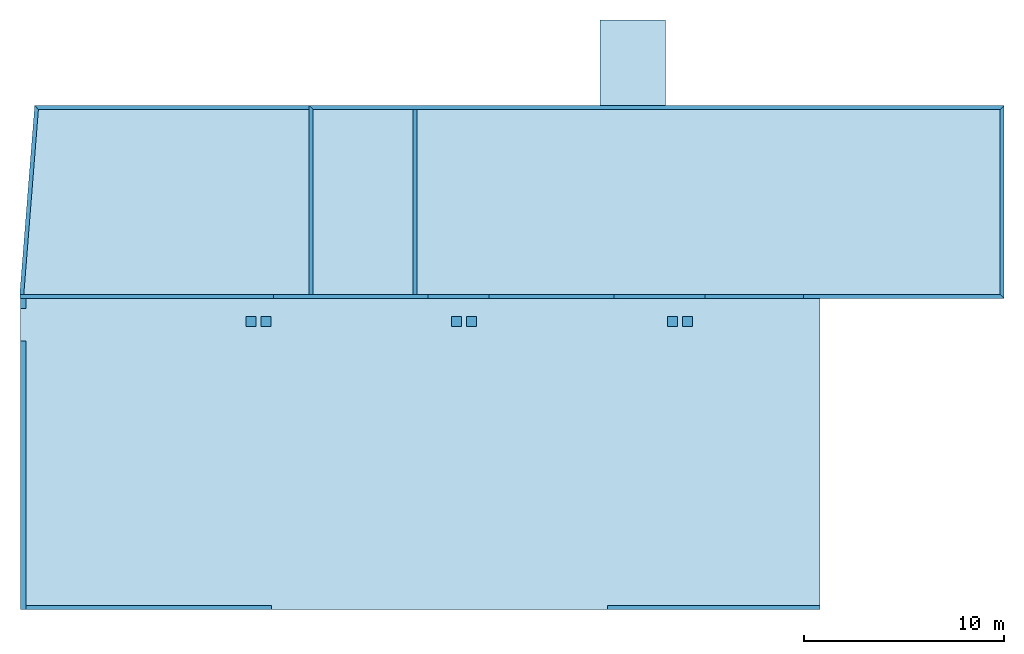
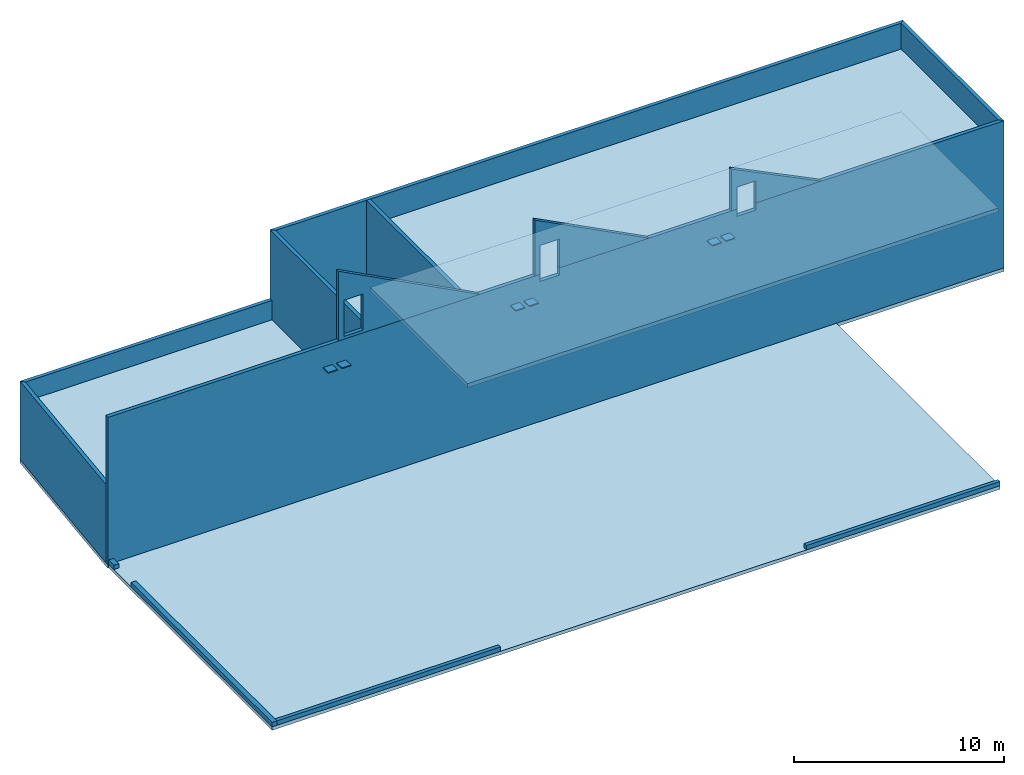
# One storey: 17 beams, 9 slabs.
"""IFC2X3 building model written with IfcOpenShell, lengths in millimetres."""

from ifc_helpers import new_model, si_unit, frame, origin_with_axes, origin_2d_with_axis, place, context, subcontext, project, spatial, polyline, rectangle, outline, extrude, boolean, clip, halfspace, material, layer, layer_set, layer_usage, type_object, element, save


model = new_model("IFC2X3")

# Units and contexts
model_context = context("Model", 3, precision=1e-05, world=origin_with_axes())
body_context = subcontext(model_context, "Body", "Model", "MODEL_VIEW")
ifc_project = project(units=[si_unit("LENGTHUNIT", "METRE", prefix="MILLI"), si_unit("AREAUNIT", "SQUARE_METRE"), si_unit("VOLUMEUNIT", "CUBIC_METRE"), si_unit("MASSUNIT", "GRAM", prefix="KILO"), si_unit("TIMEUNIT", "SECOND"), si_unit("PLANEANGLEUNIT", "RADIAN"), si_unit("SOLIDANGLEUNIT", "STERADIAN"), si_unit("THERMODYNAMICTEMPERATUREUNIT", "DEGREE_CELSIUS"), si_unit("LUMINOUSINTENSITYUNIT", "LUMEN")], contexts=[model_context])

# Site, building, storey
site_placement = place(None, origin_with_axes())
site = spatial("IfcSite", under=ifc_project, at=site_placement, CompositionType="ELEMENT")
building_placement = place(site_placement, origin_with_axes())
building = spatial("IfcBuilding", under=site, at=building_placement, Name="Undefined", CompositionType="ELEMENT")
storey_placement = place(building_placement, origin_with_axes())
storey = spatial("IfcBuildingStorey", under=building, at=storey_placement, Name="Undefined", CompositionType="ELEMENT", Elevation=0.0)

# Beams
ifc_material_1 = material(Name="CONCRETE/BETON")
beam_type_1 = type_object("IfcBeamType", PredefinedType="NOTDEFINED")
for number, where, z_axis, x_axis, name in (
    (1, (11334.9947340707, 14483.7658543466, 8020.03915601558), (-1.0, 0.0, 0.0), (0.0, -0.999506556345276, 0.0314108870108508), "DALLE SUR PLOT"),
    (2, (12084.9947340707, 14483.7658543467, 8020.03915601558), (-1.0, 0.0, 0.0), (0.0, -0.999506556345276, 0.0314108870108508), "DALLE SUR PLOT"),
    (3, (21634.9947340707, 14483.7658543466, 8020.03915601558), (-1.0, 0.0, 0.0), (0.0, -0.999506556345276, 0.0314108870108508), "DALLE SUR PLOT"),
    (4, (22384.9947340707, 14483.7658543467, 8020.03915601558), (-1.0, 0.0, 0.0), (0.0, -0.999506556345276, 0.0314108870108508), "DALLE SUR PLOT"),
    (5, (32434.9947340707, 14483.7658543466, 8020.03915601558), (-1.0, 0.0, 0.0), (0.0, -0.999506556345276, 0.0314108870108508), "DALLE SUR PLOT"),
    (6, (33184.9947340707, 14483.7658543467, 8020.03915601558), (-1.0, 0.0, 0.0), (0.0, -0.999506556345276, 0.0314108870108508), "DALLE SUR PLOT"),
):
    element("IfcBeam", number, at=place(storey_placement, frame(where, z_axis=z_axis, x_axis=x_axis)), inside=storey, type_object=beam_type_1, material=ifc_material_1, Name=name, context=body_context, shape_type="SweptSolid", body=[
        extrude(rectangle(XDim=50.0, YDim=500.0, at=origin_2d_with_axis()), frame((500.000000000063, 0.0, 0.0), z_axis=(-1.0, 0.0, 0.0), x_axis=(0.0, -1.0, 0.0)), (0.0, 0.0, 1.0), 500.0),
    ])
ifc_material_2 = material(Name="CONCRETE/C25/30")
beam_type_2 = type_object("IfcBeamType", PredefinedType="NOTDEFINED")
beam_1_placement = place(storey_placement, frame((-44.9999991534278, 13245.0066102588, 125.000000001448), z_axis=(0.0, 0.0, 1.0), x_axis=(0.0, -1.0, 0.0)))
element("IfcBeam", 7, at=beam_1_placement, inside=storey, type_object=beam_type_2, material=ifc_material_2, Name="POUTRE", context=body_context, shape_type="SweptSolid", body=[
    extrude(rectangle(XDim=270.0, YDim=250.0, at=origin_2d_with_axis()), frame((13425.0065914725, 0.0, 0.0), z_axis=(-1.0, 0.0, 0.0), x_axis=(0.0, -1.0, 0.0)), (0.0, 0.0, 1.0), 13425.01),
])
beam_2_placement = place(storey_placement, frame((-44.9999989999997, 15390.0000797396, 124.999999999849), z_axis=(0.0, 0.0, 1.0), x_axis=(0.0, -1.0, 0.0)))
element("IfcBeam", 8, at=beam_2_placement, inside=storey, type_object=beam_type_2, material=ifc_material_2, Name="POUTRE", context=body_context, shape_type="SweptSolid", body=[
    extrude(rectangle(XDim=270.0, YDim=250.0, at=origin_2d_with_axis()), frame((500.000077339644, 0.0, 0.0), z_axis=(-1.0, 0.0, 0.0), x_axis=(0.0, -1.0, 0.0)), (0.0, 0.0, 1.0), 500.0),
])
beam_type_3 = type_object("IfcBeamType", PredefinedType="NOTDEFINED")
beam_3_placement = place(storey_placement, frame((29179.9971504447, -79.9999948426784, 124.999999999172), z_axis=(0.0, 0.0, 1.0), x_axis=(1.0, 0.0, 0.0)))
element("IfcBeam", 9, at=beam_3_placement, inside=storey, type_object=beam_type_3, material=ifc_material_2, Name="POUTRE", context=body_context, shape_type="SweptSolid", body=[
    extrude(rectangle(XDim=200.0, YDim=250.0, at=origin_2d_with_axis()), frame((10645.0, 0.0, 0.0), z_axis=(-1.0, 0.0, 0.0), x_axis=(0.0, -1.0, 0.0)), (0.0, 0.0, 1.0), 10645.0),
])
beam_4_placement = place(storey_placement, frame((90.0000010000076, -79.9999811506332, 125.000000012157), z_axis=(0.0, 0.0, 1.0), x_axis=(1.0, 0.0, 0.0)))
element("IfcBeam", 10, at=beam_4_placement, inside=storey, type_object=beam_type_3, material=ifc_material_2, Name="POUTRE", context=body_context, shape_type="SweptSolid", body=[
    extrude(rectangle(XDim=200.0, YDim=250.0, at=origin_2d_with_axis()), frame((12289.9971494447, 0.0, 0.0), z_axis=(-1.0, 0.0, 0.0), x_axis=(0.0, -1.0, 0.0)), (0.0, 0.0, 1.0), 12290.0),
])
beam_type_4 = type_object("IfcBeamType", PredefinedType="NOTDEFINED")
beam_5_placement = place(storey_placement, frame((19554.9999999978, 15589.9999107527, 4275.0), z_axis=(0.0, 0.0, 1.0), x_axis=(0.0, 1.0, 0.0)))
element("IfcBeam", 11, at=beam_5_placement, inside=storey, type_object=beam_type_4, material=ifc_material_2, Name="POUTRE", context=body_context, shape_type="SweptSolid", body=[
    extrude(rectangle(XDim=200.0, YDim=8550.0, at=origin_2d_with_axis()), frame((9250.00007595538, 0.0, 0.0), z_axis=(-1.0, 0.0, 0.0), x_axis=(0.0, -1.0, 0.0)), (0.0, 0.0, 1.0), 9250.0),
])
beam_6_placement = place(storey_placement, frame((14354.9999999978, 15589.9999107527, 4275.0), z_axis=(0.0, 0.0, 1.0), x_axis=(0.0, 1.0, 0.0)))
element("IfcBeam", 12, at=beam_6_placement, inside=storey, type_object=beam_type_4, material=ifc_material_2, Name="POUTRE", context=body_context, shape_type="Clipping", body=[
    clip(extrude(rectangle(XDim=200.0, YDim=8550.0, at=origin_2d_with_axis()), frame((9451.00008924953, 0.0, 0.0), z_axis=(-1.0, 0.0, 0.0), x_axis=(0.0, -1.0, 0.0)), (0.0, 0.0, 1.0), 9451.0), halfspace(frame((9450.00008924732, 99.9999999977881, -4275.0), z_axis=(-0.707106781186548, 0.707106781186548, 0.0), x_axis=(0.0, 0.0, 1.0)), True)),
])
beam_7_placement = place(storey_placement, frame((49032.9999999964, 24939.9999999948, 4275.0), z_axis=(0.0, 0.0, 1.0), x_axis=(-1.0, 0.0, 0.0)))
solid = boolean("DIFFERENCE", boolean("DIFFERENCE", boolean("DIFFERENCE", boolean("DIFFERENCE", boolean("DIFFERENCE", boolean("DIFFERENCE", boolean("DIFFERENCE", boolean("DIFFERENCE", extrude(rectangle(XDim=200.0, YDim=8550.0, at=origin_2d_with_axis()), frame((34879.9999999912, 0.0, 0.0), z_axis=(-1.0, 0.0, 0.0), x_axis=(0.0, -1.0, 0.0)), (0.0, 0.0, 1.0), 34982.0), extrude(outline(polyline([(0.0, 0.0), (1700.0, 0.0), (1700.0, 1000.00000003092), (0.0, 1000.00000003092), (0.0, 0.0)])), frame((24712.9999993564, 103.000023915491, 1935.0), z_axis=(0.0, -1.0, 0.0), x_axis=(0.0, 0.0, -1.0)), (0.0, 0.0, 1.0), 206.0)), extrude(outline(polyline([(0.0, 0.0), (1700.0, 0.0), (1700.0, 1450.00000003092), (0.0, 1450.00000003092), (0.0, 0.0)])), frame((20657.9999993564, 103.000010491167, 1935.0), z_axis=(0.0, -1.0, 0.0), x_axis=(0.0, 0.0, -1.0)), (0.0, 0.0, 1.0), 206.0)), extrude(outline(polyline([(0.0, 0.0), (1700.0, 0.0), (1700.0, 5000.00000003056), (0.0, 5000.00000003056), (0.0, 0.0)])), frame((14593.9999993564, 102.999990415927, 1935.0), z_axis=(0.0, -1.0, 0.0), x_axis=(0.0, 0.0, -1.0)), (0.0, 0.0, 1.0), 206.0)), extrude(outline(polyline([(0.0, 0.0), (1700.0, 0.0), (1700.0, 5000.00000003056), (0.0, 5000.00000003056), (0.0, 0.0)])), frame((13029.9999999744, -103.00001476179, 1935.0), z_axis=(0.0, 1.0, 0.0), x_axis=(0.0, 0.0, -1.0)), (0.0, 0.0, 1.0), 206.0)), extrude(outline(polyline([(0.0, 0.0), (1600.00000003092, 0.0), (1600.00000003092, 2815.0), (3.09228198602796e-08, 2815.0), (0.0, 0.0)])), frame((24007.9999999744, -102.999978418455, -1460.0), z_axis=(0.0, 1.0, 0.0), x_axis=(1.0, 0.0, 0.0)), (0.0, 0.0, 1.0), 206.0)), extrude(outline(polyline([(0.0, 0.0), (1170.00000003056, 0.0), (1170.00000003056, 2815.0), (3.09228198602796e-08, 2815.0), (0.0, 0.0)])), frame((11859.9999999744, -103.000018635146, -1460.0), z_axis=(0.0, 1.0, 0.0), x_axis=(1.0, 0.0, 0.0)), (0.0, 0.0, 1.0), 206.0)), extrude(outline(polyline([(0.0, 0.0), (1990.0, 0.0), (1990.0, 2800.0), (0.0, 2800.0), (0.0, 0.0)])), frame((14330.0000000046, -103.000113208662, -1475.0), z_axis=(0.0, 1.0, 0.0), x_axis=(1.0, 0.0, 0.0)), (0.0, 0.0, 1.0), 206.0)), extrude(outline(polyline([(0.0, 0.0), (1150.00000003092, 0.0), (1150.00000003092, 2180.0), (3.09228198602796e-08, 2180.0), (0.0, 0.0)])), frame((22622.9999999744, -102.999983003581, -2095.0), z_axis=(0.0, 1.0, 0.0), x_axis=(1.0, 0.0, 0.0)), (0.0, 0.0, 1.0), 206.0))
element("IfcBeam", 13, at=beam_7_placement, inside=storey, type_object=beam_type_4, material=ifc_material_2, Name="POUTRE", context=body_context, shape_type="CSG", body=[
    boolean("DIFFERENCE", boolean("DIFFERENCE", solid, halfspace(frame((34777.9999999964, -100.00000000521, -4275.0), z_axis=(0.707106781186541, 0.707106781186554, 0.0), x_axis=(0.0, 0.0, 1.0)), False)), halfspace(frame((0.000287976654362865, -100.00000000521, -4275.0), z_axis=(0.707106781186548, -0.707106781186548, 0.0), x_axis=(0.0, 0.0, 1.0)), True)),
])
beam_8_placement = place(storey_placement, frame((48932.9999999978, 15389.9999999948, 4275.0), z_axis=(0.0, 0.0, 1.0), x_axis=(0.0, 1.0, 0.0)))
element("IfcBeam", 14, at=beam_8_placement, inside=storey, type_object=beam_type_4, material=ifc_material_2, Name="POUTRE", context=body_context, shape_type="Clipping", body=[
    clip(clip(extrude(rectangle(XDim=200.0, YDim=8550.0, at=origin_2d_with_axis()), frame((9752.0002879832, 0.0, 0.0), z_axis=(-1.0, 0.0, 0.0), x_axis=(0.0, -1.0, 0.0)), (0.0, 0.0, 1.0), 9854.0), halfspace(frame((9650.0001439916, -99.9998560083986, -4275.0), z_axis=(0.707106781186541, 0.707106781186554, 0.0), x_axis=(0.0, 0.0, 1.0)), False)), halfspace(frame((200.000153575076, 100.000729531086, -4275.0), z_axis=(-0.707106781186548, 0.707106781186548, 0.0), x_axis=(0.0, 0.0, 1.0)), False)),
])
beam_9_placement = place(storey_placement, frame((49033.0, 15490.0, 4275.0), z_axis=(0.0, 0.0, 1.0), x_axis=(-1.0, 0.0, 0.0)))
element("IfcBeam", 15, at=beam_9_placement, inside=storey, type_object=beam_type_4, material=ifc_material_2, Name="POUTRE", context=body_context, shape_type="CSG", body=[
    boolean("DIFFERENCE", boolean("DIFFERENCE", boolean("DIFFERENCE", extrude(rectangle(XDim=200.0, YDim=8550.0, at=origin_2d_with_axis()), frame((49248.0, 0.0, 0.0), z_axis=(-1.0, 0.0, 0.0), x_axis=(0.0, -1.0, 0.0)), (0.0, 0.0, 1.0), 49249.0), extrude(outline(polyline([(0.0, 0.0), (420.000061035156, 0.0), (420.000061035156, 1065.0), (0.0, 1065.0), (0.0, 0.0)])), frame((25496.5000000001, -102.5, 4275.00006282721), z_axis=(0.0, 1.0, 0.0), x_axis=(0.0, 0.0, -1.0)), (0.0, 0.0, 1.0), 205.0)), extrude(outline(polyline([(0.0, 0.0), (419.999969482422, 0.0), (419.999969482422, 1065.0), (0.0, 1065.0), (0.0, 0.0)])), frame((14686.5, -102.5, 4274.99997731322), z_axis=(0.0, 1.0, 0.0), x_axis=(0.0, 0.0, -1.0)), (0.0, 0.0, 1.0), 205.0)), halfspace(frame((200.000729533298, -100.000153569881, -4275.0), z_axis=(0.707106781186541, 0.707106781186554, 0.0), x_axis=(0.0, 0.0, 1.0)), True)),
])
beam_type_5 = type_object("IfcBeamType", PredefinedType="NOTDEFINED")
beam_10_placement = place(storey_placement, frame((14255.0, 24939.9999999948, 2275.0), z_axis=(0.0, 0.0, 1.0), x_axis=(-1.0, 0.0, 0.0)))
element("IfcBeam", 16, at=beam_10_placement, inside=storey, type_object=beam_type_5, material=ifc_material_2, Name="POUTRE", context=body_context, shape_type="Clipping", body=[
    clip(extrude(rectangle(XDim=200.0, YDim=4550.0, at=origin_2d_with_axis()), frame((13734.3312485234, 0.0, 0.0), z_axis=(-1.0, 0.0, 0.0), x_axis=(0.0, -1.0, 0.0)), (0.0, 0.0, 1.0), 13734.33), halfspace(frame((13548.592821132, 100.000000369644, -2275.0), z_axis=(-0.734439176294991, -0.67867451427259, 0.0), x_axis=(0.0, 0.0, 1.0)), True)),
])
beam_11_placement = place(storey_placement, frame((621.281853417001, 25032.1198194901, 2274.99999999225), z_axis=(0.0, 0.0, 1.0), x_axis=(-0.0788018049729438, -0.996890302657723, 0.0)))
element("IfcBeam", 17, at=beam_11_placement, inside=storey, type_object=beam_type_5, material=ifc_material_2, Name="POUTRE", context=body_context, shape_type="Clipping", body=[
    clip(clip(clip(extrude(rectangle(XDim=200.0, YDim=4550.0, at=origin_2d_with_axis()), frame((9586.76964239357, 1.33043154859535e-13, 4.54747350886464e-13), z_axis=(-1.0, 0.0, 0.0), x_axis=(0.0, -1.0, 0.0)), (0.0, 0.0, 1.0), 9609.56), halfspace(frame((100.311939798736, -830.961129115268, -2275.0), z_axis=(0.0788018049729438, -0.996890302657723, 0.0), x_axis=(0.0, 0.0, 1.0)), False)), halfspace(frame((9478.06434405287, -82.1124981129219, -2274.99999999225), z_axis=(0.996890302657721, 0.0788018049729664, 0.0), x_axis=(0.0, 0.0, 1.0)), False)), halfspace(frame((184.814356077273, 100.000000029129, -2274.99999999225), z_axis=(-0.734439174674176, 0.678674516026582, 0.0), x_axis=(0.0, 0.0, 1.0)), False)),
])

# Slabs
ifc_layer_1 = layer(ifc_material_2, 200.0)
ifc_layer_set_1 = layer_set([ifc_layer_1], Name="Floor: Insitu CONCRETE/C25/30")
ifc_layer_usage_1 = layer_usage(ifc_layer_set_1, "AXIS3", "POSITIVE", -100.0)
slab_type_1 = type_object("IfcSlabType", PredefinedType="NOTDEFINED")
slab_1_placement = place(storey_placement, frame((14455.0, 24839.9999999948, 3325.0), z_axis=(0.0, 0.0, 1.0), x_axis=(0.0, -1.0, 0.0)))
element("IfcSlab", 18, at=slab_1_placement, inside=storey, type_object=slab_type_1, material=ifc_layer_usage_1, Name="DALLE", PredefinedType="FLOOR", context=body_context, shape_type="SweptSolid", body=[
    extrude(outline(polyline([(0.0, 0.0), (9250.0, 3.63797880709171e-12), (9250.0009765625, 4999.998046875), (0.000105106431874447, 5000.0), (0.0, 0.0)])), frame((0.0, 0.0, -100.0), z_axis=(0.0, 0.0, 1.0), x_axis=(1.0, 0.0, 0.0)), (0.0, 0.0, 1.0), 200.0),
])
ifc_layer_usage_2 = layer_usage(ifc_layer_set_1, "AXIS3", "POSITIVE", -100.0)
slab_type_2 = type_object("IfcSlabType", PredefinedType="NOTDEFINED")
slab_2_placement = place(storey_placement, frame((39824.9971504447, -180.0, -100.0), z_axis=(0.0, 0.0, 1.0), x_axis=(0.0, 1.0, 0.0)))
element("IfcSlab", 19, at=slab_2_placement, inside=storey, type_object=slab_type_2, material=ifc_layer_usage_2, Name="DALLE", PredefinedType="FLOOR", context=body_context, shape_type="SweptSolid", body=[
    extrude(outline(polyline([(0.0, 0.0), (15570.0, -2.73066689260304e-08), (15569.9999999648, 40004.9960937226), (-6.12302781917151e-05, 40004.99609375), (0.0, 0.0)])), frame((0.0, 0.0, -100.0), z_axis=(0.0, 0.0, 1.0), x_axis=(1.0, 0.0, 0.0)), (0.0, 0.0, 1.0), 200.0),
])
ifc_layer_usage_3 = layer_usage(ifc_layer_set_1, "AXIS3", "POSITIVE", -100.0)
slab_type_3 = type_object("IfcSlabType", PredefinedType="NOTDEFINED")
slab_3_placement = place(storey_placement, frame((34063.5, 15489.999472991, 10975.4455339538), z_axis=(0.0, -1.0, 0.0), x_axis=(0.0, 0.0, -1.0)))
element("IfcSlab", 20, at=slab_3_placement, inside=storey, type_object=slab_type_3, material=ifc_layer_usage_3, Name="DALLE", PredefinedType="FLOOR", context=body_context, shape_type="CSG", body=[
    boolean("DIFFERENCE", extrude(outline(polyline([(0.0, 0.0), (2425.44555664063, 0.0), (2425.44555664063, 4933.109375), (0.0, 0.0)])), frame((0.0, 0.0, -100.0), z_axis=(0.0, 0.0, 1.0), x_axis=(1.0, 0.0, 0.0)), (0.0, 0.0, 1.0), 200.0), extrude(outline(polyline([(0.0, 0.0), (1700.0, 0.0), (1700.0, 1065.0), (0.0, 1065.0), (0.0, 0.0)])), frame((1145.44553395384, 1348.0, 102.5), z_axis=(0.0, 0.0, -1.0), x_axis=(1.0, 0.0, 0.0)), (0.0, 0.0, 1.0), 205.0)),
])
ifc_layer_usage_4 = layer_usage(ifc_layer_set_1, "AXIS3", "POSITIVE", -100.0)
slab_type_4 = type_object("IfcSlabType", PredefinedType="NOTDEFINED")
slab_4_placement = place(storey_placement, frame((23253.5000017513, 15489.9996870349, 11799.0364397802), z_axis=(0.0, -1.0, 0.0), x_axis=(0.0, 0.0, -1.0)))
element("IfcSlab", 21, at=slab_4_placement, inside=storey, type_object=slab_type_4, material=ifc_layer_usage_4, Name="DALLE", PredefinedType="FLOOR", context=body_context, shape_type="CSG", body=[
    boolean("DIFFERENCE", extrude(outline(polyline([(0.0, 0.0), (3249.03637695294, 4.86907083541155e-08), (3249.03637695294, 6269.86816411125), (0.0, 0.0)])), frame((0.0, 0.0, -100.0), z_axis=(0.0, 0.0, 1.0), x_axis=(1.0, 0.0, 0.0)), (0.0, 0.0, 1.0), 200.0), extrude(outline(polyline([(0.0, 0.0), (2100.0, 0.0), (2100.0, 1065.0), (0.0, 1065.0), (0.0, 0.0)])), frame((1569.03643978015, 282.999996394619, -102.999948665183), z_axis=(0.0, 0.0, 1.0), x_axis=(1.0, 0.0, 0.0)), (0.0, 0.0, 1.0), 206.0)),
])
ifc_layer_usage_5 = layer_usage(ifc_layer_set_1, "AXIS3", "POSITIVE", -100.0)
slab_type_5 = type_object("IfcSlabType", PredefinedType="NOTDEFINED")
slab_5_placement = place(storey_placement, frame((12463.5000011269, 15489.9997800704, 12602.0151979852), z_axis=(0.0, -1.0, 0.0), x_axis=(0.0, 0.0, -1.0)))
element("IfcSlab", 22, at=slab_5_placement, inside=storey, type_object=slab_type_5, material=ifc_layer_usage_5, Name="DALLE", PredefinedType="FLOOR", context=body_context, shape_type="CSG", body=[
    boolean("DIFFERENCE", extrude(outline(polyline([(0.0, 0.0), (4052.01513671857, -2.6855559553951e-08), (4052.01489257794, 7745.84130856683), (0.0, 0.0)])), frame((0.0, 0.0, -100.0), z_axis=(0.0, 0.0, 1.0), x_axis=(1.0, 0.0, 0.0)), (0.0, 0.0, 1.0), 200.0), extrude(outline(polyline([(0.0, 0.0), (2100.0, 0.0), (2100.0, 1065.0), (6.12666408414952e-05, 1065.0), (0.0, 0.0)])), frame((1782.01513671857, 283.009997740204, -102.999960510979), z_axis=(0.0, 0.0, 1.0), x_axis=(1.0, 0.0, 0.0)), (0.0, 0.0, 1.0), 206.0)),
])
ifc_layer_usage_6 = layer_usage(ifc_layer_set_1, "AXIS3", "POSITIVE", -100.0)
slab_type_6 = type_object("IfcSlabType", PredefinedType="NOTDEFINED")
slab_6_placement = place(storey_placement, frame((521.592823151228, 25040.0000000261, -100.0), z_axis=(0.0, 0.0, 1.0), x_axis=(-0.0788018049729438, -0.996890302657723, 0.0)))
element("IfcSlab", 23, at=slab_6_placement, inside=storey, type_object=slab_type_6, material=ifc_layer_usage_6, Name="DALLE", PredefinedType="FLOOR", context=body_context, shape_type="SweptSolid", body=[
    extrude(outline(polyline([(0.0, 0.0), (9347.4101561871, -3.21924744639546e-08), (9678.03613274741, 26.1351794842228), (5797.20556643842, 49120.988281209), (-3822.78637685732, 48360.5507812445), (-2487.88403314078, 31473.2304687464), (-6754.57421865942, 31135.9570312622), (-6496.1044921034, 27866.1582031375), (-2229.41406244413, 28203.4296874968), (0.0, 0.0)])), frame((0.0, 0.0, -100.0), z_axis=(0.0, 0.0, 1.0), x_axis=(1.0, 0.0, 0.0)), (0.0, 0.0, 1.0), 200.0),
])
ifc_layer_2 = layer(ifc_material_2, 230.0)
ifc_layer_set_2 = layer_set([ifc_layer_2], Name="Floor: Insitu CONCRETE/C25/30")
ifc_layer_usage_7 = layer_usage(ifc_layer_set_2, "AXIS3", "POSITIVE", -115.0)
slab_type_7 = type_object("IfcSlabType", PredefinedType="NOTDEFINED")
slab_7_placement = place(storey_placement, frame((19655.0, 24839.9999999948, 3310.0), z_axis=(0.0, 0.0, 1.0), x_axis=(0.0, -1.0, 0.0)))
element("IfcSlab", 24, at=slab_7_placement, inside=storey, type_object=slab_type_7, material=ifc_layer_usage_7, Name="DALLE", PredefinedType="FLOOR", context=body_context, shape_type="SweptSolid", body=[
    extrude(outline(polyline([(0.0, 0.0), (9250.0, 3.63797880709171e-12), (9250.0009765625, 29177.998046875), (0.000105106431874447, 29178.0), (0.0, 0.0)])), frame((0.0, 0.0, -115.0), z_axis=(0.0, 0.0, 1.0), x_axis=(1.0, 0.0, 0.0)), (0.0, 0.0, 1.0), 230.0),
])
ifc_layer_usage_8 = layer_usage(ifc_layer_set_2, "AXIS3", "POSITIVE", -115.0)
slab_8_placement = place(storey_placement, frame((706.407178868009, 24839.9999996251, 3310.0), z_axis=(0.0, 0.0, 1.0), x_axis=(-0.0788018049729438, -0.996890302657723, 0.0)))
element("IfcSlab", 25, at=slab_8_placement, inside=storey, type_object=slab_type_7, material=ifc_layer_usage_8, Name="DALLE", PredefinedType="FLOOR", context=body_context, shape_type="SweptSolid", body=[
    extrude(outline(polyline([(0.0, 0.0), (9278.85351568104, 3.96833002014318e-08), (8153.59130869161, 14235.3720703537), (-1067.64440914001, 13506.4628906271), (0.0, 0.0)])), frame((0.0, 0.0, -115.0), z_axis=(0.0, 0.0, 1.0), x_axis=(1.0, 0.0, 0.0)), (0.0, 0.0, 1.0), 230.0),
])
ifc_layer_3 = layer(ifc_material_2, 220.0)
ifc_layer_set_3 = layer_set([ifc_layer_3], Name="Floor: Insitu CONCRETE/C25/30")
ifc_layer_usage_9 = layer_usage(ifc_layer_set_3, "AXIS3", "POSITIVE", -110.0)
slab_type_8 = type_object("IfcSlabType", PredefinedType="NOTDEFINED")
slab_9_placement = place(storey_placement, frame((19655.0, 24839.9999999948, 6940.0), z_axis=(0.0, 0.0, 1.0), x_axis=(0.0, -1.0, 0.0)))
element("IfcSlab", 26, at=slab_9_placement, inside=storey, type_object=slab_type_8, material=ifc_layer_usage_9, Name="DALLE", PredefinedType="FLOOR", context=body_context, shape_type="SweptSolid", body=[
    extrude(outline(polyline([(0.0, 0.0), (9250.0, 3.63797880709171e-12), (9250.0009765625, 29177.998046875), (0.000105106431874447, 29178.0), (0.0, 0.0)])), frame((0.0, 0.0, -110.0), z_axis=(0.0, 0.0, 1.0), x_axis=(1.0, 0.0, 0.0)), (0.0, 0.0, 1.0), 220.0),
])

save(model, "model.ifc")
